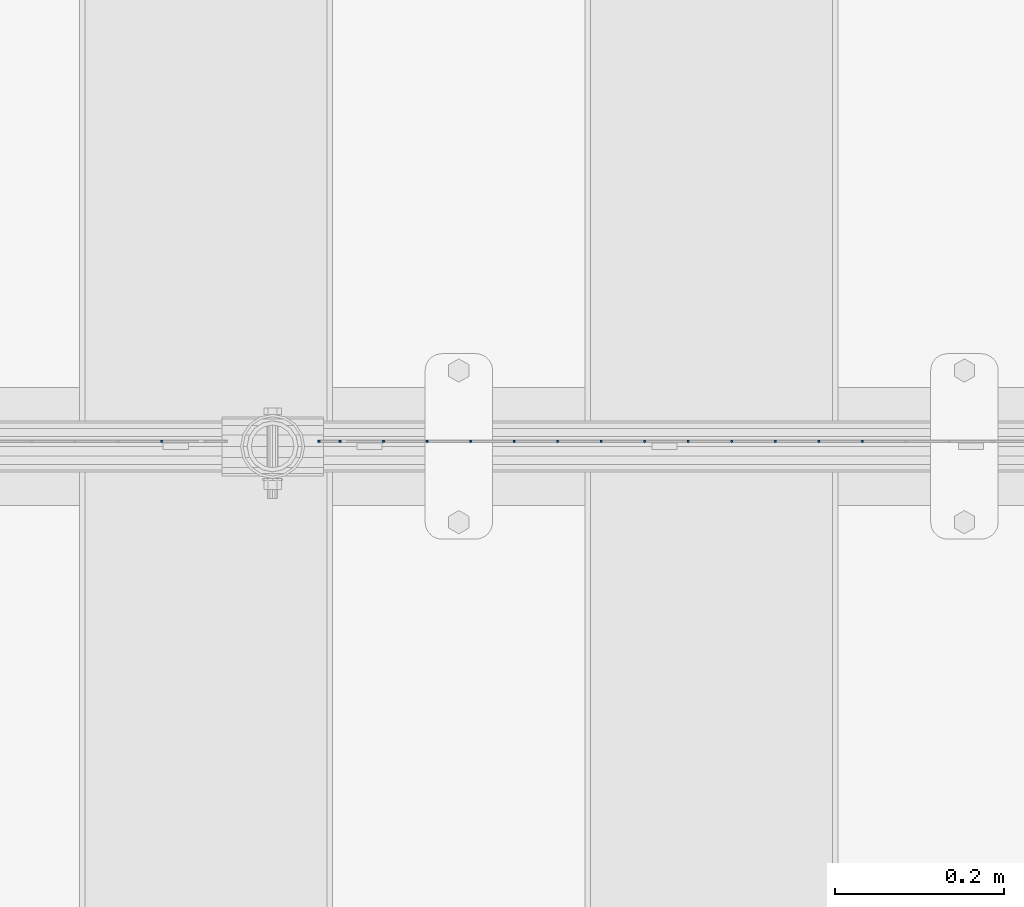
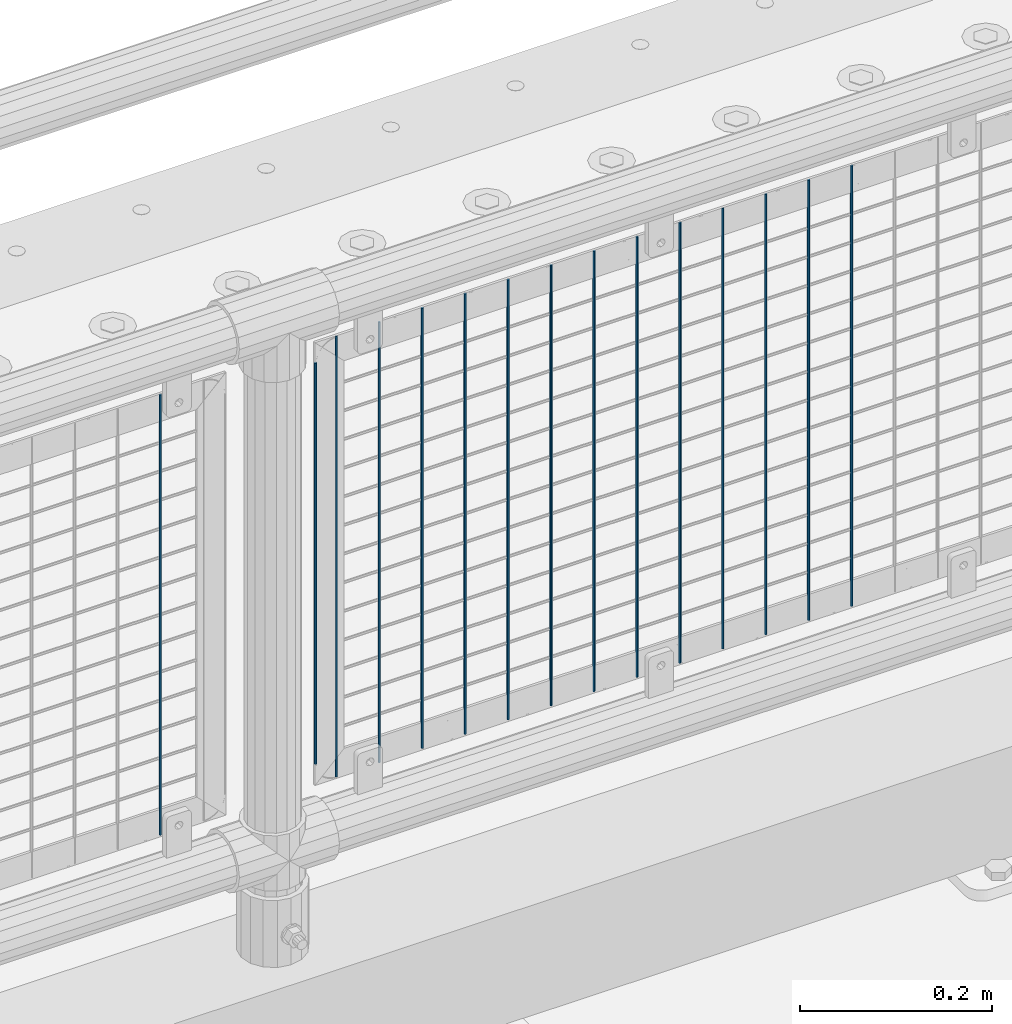
# One storey, part 70 of 240: 15 columns.
"""IFC2X3 building model written with IfcOpenShell, lengths in millimetres."""

from ifc_helpers import new_model, si_unit, frame, origin_with_axes, place, context, subcontext, project, spatial, faceted_brep, material, type_object, element, save


model = new_model("IFC2X3")

# Units and contexts
model_context = context("Model", 3, precision=1e-05, world=origin_with_axes())
body_context = subcontext(model_context, "Body", "Model", "MODEL_VIEW")
ifc_project = project(units=[si_unit("LENGTHUNIT", "METRE", prefix="MILLI"), si_unit("AREAUNIT", "SQUARE_METRE"), si_unit("VOLUMEUNIT", "CUBIC_METRE"), si_unit("MASSUNIT", "GRAM", prefix="KILO"), si_unit("TIMEUNIT", "SECOND"), si_unit("PLANEANGLEUNIT", "RADIAN"), si_unit("SOLIDANGLEUNIT", "STERADIAN"), si_unit("THERMODYNAMICTEMPERATUREUNIT", "DEGREE_CELSIUS"), si_unit("LUMINOUSINTENSITYUNIT", "LUMEN")], contexts=[model_context])

# Site, building, storey
site_placement = place(None, origin_with_axes())
site = spatial("IfcSite", under=ifc_project, at=site_placement, CompositionType="ELEMENT")
building_placement = place(site_placement, origin_with_axes())
building = spatial("IfcBuilding", under=site, at=building_placement, Name="Standard", CompositionType="ELEMENT")
storey_placement = place(building_placement, origin_with_axes())
storey = spatial("IfcBuildingStorey", under=building, at=storey_placement, Name="Undefined", CompositionType="ELEMENT", Elevation=0.0)

# Columns
ifc_material = material(Name="Misc_Undefined")
column_type = type_object("IfcColumnType", Name="D3", PredefinedType="NOTDEFINED")
for number, where, z_axis, x_axis in (
    (1, (45428.86, 34670.5, 353.02), (-1.0, 0.0, 0.0), (0.0, 0.0, 1.0)),
    (2, (45377.205, 34670.5, 353.02), (-1.0, 0.0, 0.0), (0.0, 0.0, 1.0)),
    (3, (45325.55, 34670.5, 353.02), (-1.0, 0.0, 0.0), (0.0, 0.0, 1.0)),
    (4, (45273.895, 34670.5, 353.02), (-1.0, 0.0, 0.0), (0.0, 0.0, 1.0)),
    (5, (45222.24, 34670.5, 353.02), (-1.0, 0.0, 0.0), (0.0, 0.0, 1.0)),
    (6, (45170.585, 34670.5, 353.02), (-1.0, 0.0, 0.0), (0.0, 0.0, 1.0)),
    (7, (45118.93, 34670.5, 353.02), (-1.0, 0.0, 0.0), (0.0, 0.0, 1.0)),
    (8, (45067.275, 34670.5, 353.02), (-1.0, 0.0, 0.0), (0.0, 0.0, 1.0)),
    (9, (45015.62, 34670.5, 353.02), (-1.0, 0.0, 0.0), (0.0, 0.0, 1.0)),
    (10, (44963.965, 34670.5, 353.02), (-1.0, 0.0, 0.0), (0.0, 0.0, 1.0)),
    (11, (44912.31, 34670.5, 353.02), (-1.0, 0.0, 0.0), (0.0, 0.0, 1.0)),
    (12, (44860.655, 34670.5, 353.02), (-1.0, 0.0, 0.0), (0.0, 0.0, 1.0)),
):
    element("IfcColumn", number, at=place(storey_placement, frame(where, z_axis=z_axis, x_axis=x_axis)), inside=storey, type_object=column_type, material=ifc_material, ObjectType="D3", context=body_context, shape_type="Brep", body=[
        faceted_brep([(-7.27595761418343e-12, -1.49999999999272, 0.0), (-7.27595761418343e-12, -0.749999999992724, -1.29903810567669), (560.0, -0.75, -1.29903810567339), (560.0, -1.5, 0.0), (0.0, 0.750000000007276, -1.29903810567669), (560.0, 0.75, -1.29903810567339), (0.0, 1.50000000000728, 0.0), (560.0, 1.5, 0.0), (0.0, 0.750000000007276, 1.29903810567669), (560.0, 0.75, 1.29903810567339), (-7.27595761418343e-12, -0.749999999992724, 1.29903810567669), (560.0, -0.75, 1.29903810567339)], [[[0, 1, 2, 3]], [[1, 4, 5, 2]], [[4, 6, 7, 5]], [[6, 8, 9, 7]], [[8, 10, 11, 9]], [[10, 0, 3, 11]], [[5, 7, 9, 11, 3, 2]], [[10, 8, 6, 4, 1, 0]]]),
    ])
column_placement = place(storey_placement, frame((44784.0, 34670.5, 378.02), z_axis=(-1.0, 0.0, 0.0), x_axis=(0.0, 0.0, 1.0)))
element("IfcColumn", 13, at=column_placement, inside=storey, type_object=column_type, material=ifc_material, ObjectType="D3", context=body_context, shape_type="Brep", body=[
    faceted_brep([(-7.27595761418343e-12, -1.49999999999272, 0.0), (-7.27595761418343e-12, -0.749999999992724, -1.29903810567669), (510.0, -0.75, -1.29903810567339), (510.0, -1.5, 0.0), (0.0, 0.750000000007276, -1.29903810567669), (510.0, 0.75, -1.29903810567339), (0.0, 1.50000000000728, 0.0), (510.0, 1.5, 0.0), (0.0, 0.750000000007276, 1.29903810567669), (510.0, 0.75, 1.29903810567339), (-7.27595761418343e-12, -0.749999999992724, 1.29903810567669), (510.0, -0.75, 1.29903810567339)], [[[0, 1, 2, 3]], [[1, 4, 5, 2]], [[4, 6, 7, 5]], [[6, 8, 9, 7]], [[8, 10, 11, 9]], [[10, 0, 3, 11]], [[5, 7, 9, 11, 3, 2]], [[10, 8, 6, 4, 1, 0]]]),
])
for number, where, z_axis, x_axis in (
    (14, (44809.0, 34670.5, 353.02), (-1.0, 0.0, 0.0), (0.0, 0.0, 1.0)),
    (15, (44597.34, 34670.5, 353.02), (-1.0, 0.0, 0.0), (0.0, 0.0, 1.0)),
):
    element("IfcColumn", number, at=place(storey_placement, frame(where, z_axis=z_axis, x_axis=x_axis)), inside=storey, type_object=column_type, material=ifc_material, ObjectType="D3", context=body_context, shape_type="Brep", body=[
        faceted_brep([(-7.27595761418343e-12, -1.49999999999272, 0.0), (-7.27595761418343e-12, -0.749999999992724, -1.29903810567669), (560.0, -0.75, -1.29903810567339), (560.0, -1.5, 0.0), (0.0, 0.750000000007276, -1.29903810567669), (560.0, 0.75, -1.29903810567339), (0.0, 1.50000000000728, 0.0), (560.0, 1.5, 0.0), (0.0, 0.750000000007276, 1.29903810567669), (560.0, 0.75, 1.29903810567339), (-7.27595761418343e-12, -0.749999999992724, 1.29903810567669), (560.0, -0.75, 1.29903810567339)], [[[0, 1, 2, 3]], [[1, 4, 5, 2]], [[4, 6, 7, 5]], [[6, 8, 9, 7]], [[8, 10, 11, 9]], [[10, 0, 3, 11]], [[5, 7, 9, 11, 3, 2]], [[10, 8, 6, 4, 1, 0]]]),
    ])

save(model, "model.ifc")
